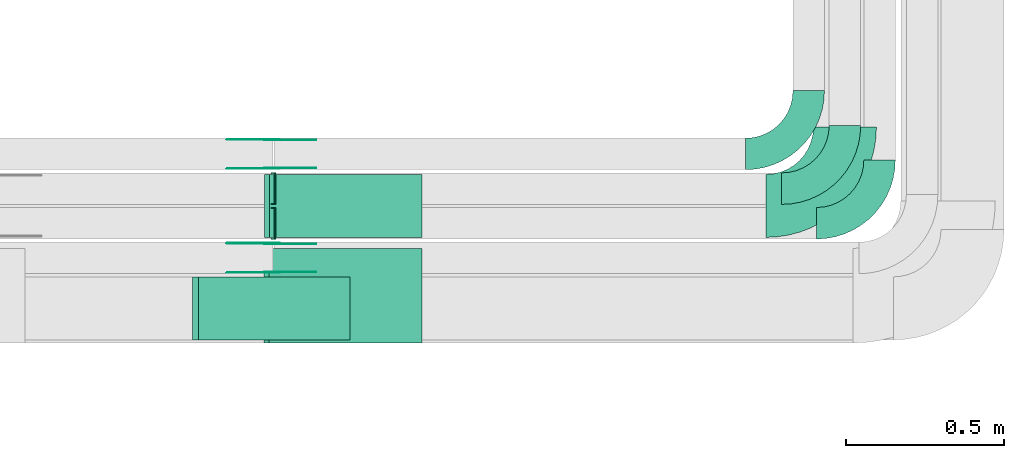
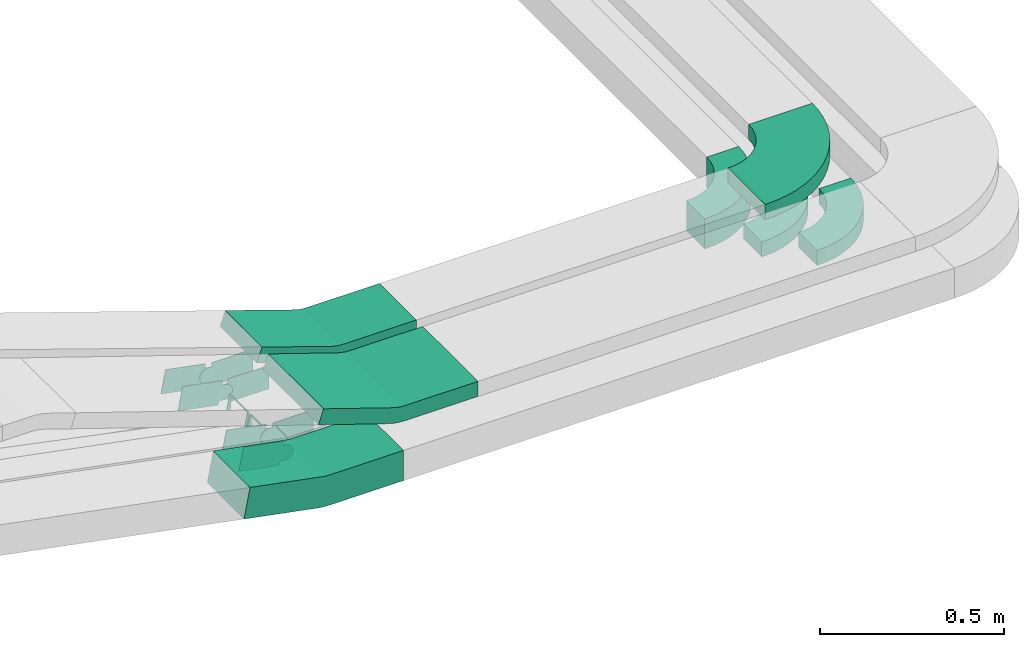
# One storey, part 28 of 31: 17 flow fittings.
"""IFC2X3 building model written with IfcOpenShell, lengths in millimetres."""

from ifc_helpers import new_model, entity, si_unit, converted_unit, derived_unit, direction, frame, frame_2d, origin, place, context, subcontext, project, spatial, polyline, circle_curve, parameter, trimmed, segment, composite_curve, outline, extrude, faceted_brep, source, transform, mapped, material, type_object, type_shapes, element, save


model = new_model("IFC2X3")

# Units and contexts
model_context = context("Model", 3, precision=0.01, world=origin(), true_north=direction((6.12303176911189e-17, 1.0)))
body_context = subcontext(model_context, "Body", "Model", "MODEL_VIEW")
ifc_project = project(units=[si_unit("LENGTHUNIT", "METRE", prefix="MILLI"), si_unit("AREAUNIT", "SQUARE_METRE"), si_unit("VOLUMEUNIT", "CUBIC_METRE"), converted_unit("PLANEANGLEUNIT", "DEGREE", entity("IfcRatioMeasure", 0.0174532925199433), si_unit("PLANEANGLEUNIT", "RADIAN"), dimensions=[0, 0, 0, 0, 0, 0, 0]), si_unit("MASSUNIT", "GRAM", prefix="KILO"), derived_unit("MASSDENSITYUNIT", [(si_unit("MASSUNIT", "GRAM", prefix="KILO"), 1), (si_unit("LENGTHUNIT", "METRE"), -3)]), derived_unit("MOMENTOFINERTIAUNIT", [(si_unit("LENGTHUNIT", "METRE"), 4)]), si_unit("TIMEUNIT", "SECOND"), si_unit("FREQUENCYUNIT", "HERTZ"), si_unit("THERMODYNAMICTEMPERATUREUNIT", "DEGREE_CELSIUS"), derived_unit("THERMALTRANSMITTANCEUNIT", [(si_unit("MASSUNIT", "GRAM", prefix="KILO"), 1), (si_unit("THERMODYNAMICTEMPERATUREUNIT", "KELVIN"), -1), (si_unit("TIMEUNIT", "SECOND"), -3)]), derived_unit("VOLUMETRICFLOWRATEUNIT", [(si_unit("LENGTHUNIT", "METRE"), 3), (si_unit("TIMEUNIT", "SECOND"), -1)]), derived_unit("MASSFLOWRATEUNIT", [(si_unit("MASSUNIT", "GRAM", prefix="KILO"), 1), (si_unit("TIMEUNIT", "SECOND"), -1)]), derived_unit("ROTATIONALFREQUENCYUNIT", [(si_unit("TIMEUNIT", "SECOND"), -1)]), si_unit("ELECTRICCURRENTUNIT", "AMPERE"), si_unit("ELECTRICVOLTAGEUNIT", "VOLT"), si_unit("POWERUNIT", "WATT"), si_unit("FORCEUNIT", "NEWTON", prefix="KILO"), si_unit("ILLUMINANCEUNIT", "LUX"), si_unit("LUMINOUSFLUXUNIT", "LUMEN"), si_unit("LUMINOUSINTENSITYUNIT", "CANDELA"), derived_unit("USERDEFINED", [(si_unit("MASSUNIT", "GRAM", prefix="KILO"), -1), (si_unit("LENGTHUNIT", "METRE"), -2), (si_unit("TIMEUNIT", "SECOND"), 3), (si_unit("LUMINOUSFLUXUNIT", "LUMEN"), 1)]), derived_unit("LINEARVELOCITYUNIT", [(si_unit("LENGTHUNIT", "METRE"), 1), (si_unit("TIMEUNIT", "SECOND"), -1)]), si_unit("PRESSUREUNIT", "PASCAL"), derived_unit("USERDEFINED", [(si_unit("LENGTHUNIT", "METRE"), -2), (si_unit("MASSUNIT", "GRAM", prefix="KILO"), 1), (si_unit("TIMEUNIT", "SECOND"), -2)]), derived_unit("LINEARFORCEUNIT", [(si_unit("MASSUNIT", "GRAM", prefix="KILO"), 1), (si_unit("LENGTHUNIT", "METRE"), 1), (si_unit("TIMEUNIT", "SECOND"), -2), (si_unit("LENGTHUNIT", "METRE"), -1)]), derived_unit("PLANARFORCEUNIT", [(si_unit("MASSUNIT", "GRAM", prefix="KILO"), 1), (si_unit("LENGTHUNIT", "METRE"), 1), (si_unit("TIMEUNIT", "SECOND"), -2), (si_unit("LENGTHUNIT", "METRE"), -2)])], contexts=[model_context])

# Site, building, storey
site_placement = place(None, frame((0.0, -0.00077364408347762, 0.0)))
site = spatial("IfcSite", under=ifc_project, at=site_placement, CompositionType="ELEMENT")
building_placement = place(site_placement, origin())
building = spatial("IfcBuilding", under=site, at=building_placement, CompositionType="ELEMENT")
storey_placement = place(building_placement, frame((0.0, 0.0, 15900.0)))
storey = spatial("IfcBuildingStorey", under=building, at=storey_placement, CompositionType="ELEMENT", Elevation=15900.0)

# Flow fittings
ifc_material_1 = material()
cable_carrier_fitting_type_1 = type_object("IfcCableCarrierFittingType", Name="470_DKC_S5_Variable Angle Elbow 0-45:-", PredefinedType="NOTDEFINED", material=ifc_material_1)
shared_shape_1 = source(origin(), body_context, "Body", "SweptSolid", [
    extrude(outline(composite_curve([segment(polyline([(-100.749999999999, -150.250000000001), (-99.7499999999981, -150.250000000001)]), True, "CONTINUOUS"), segment(trimmed(circle_curve(frame_2d((-99.7500000000006, 99.7499999999987), x_axis=(0.0, -1.0)), 250.0), [parameter(0.0)], [parameter(90.0000000000001)], True, "PARAMETER"), True, "CONTINUOUS"), segment(polyline([(150.249999999999, 99.7500000000013), (150.249999999999, 100.750000000001)]), True, "CONTINUOUS"), segment(polyline([(150.249999999999, 100.750000000001), (50.2499999999992, 100.750000000001)]), True, "CONTINUOUS"), segment(polyline([(50.2499999999992, 100.750000000001), (50.2499999999992, 99.7500000000002)]), True, "CONTINUOUS"), segment(trimmed(circle_curve(frame_2d((-99.7500000000006, 99.7499999999987), x_axis=(0.0, -1.0)), 150.0), [parameter(0.0)], [parameter(90.0000000000001)], True, "PARAMETER"), False, "CONTINUOUS"), segment(polyline([(-99.7499999999989, -50.2500000000011), (-100.75, -50.2500000000011)]), True, "CONTINUOUS"), segment(polyline([(-100.75, -50.2500000000011), (-100.749999999999, -150.250000000001)]), True, "CONTINUOUS")], self_intersect=False)), frame((-100.249999999991, 100.249999999992, -50.0)), (0.0, 0.0, 1.0), 100.0),
])
type_shapes(cable_carrier_fitting_type_1, [shared_shape_1])
flow_fitting_1_placement = place(storey_placement, frame((68357.9446589115, 9064.96586239508, 2645.87316402395)))
element("IfcFlowFitting", 1, at=flow_fitting_1_placement, inside=storey, type_object=cable_carrier_fitting_type_1, material=ifc_material_1, Name="470_DKC_S5_Variable Angle Elbow 0-45:-", ObjectType="470_DKC_S5_Variable Angle Elbow 0-45:-", context=body_context, shape_type="MappedRepresentation", body=[
    mapped(shared_shape_1, transform((0.0, 0.0, 0.0), scale=1.0)),
])
cable_carrier_fitting_type_2 = type_object("IfcCableCarrierFittingType", Name="470_DKC_S5_Variable Angle Elbow 0-45:-", PredefinedType="NOTDEFINED", material=ifc_material_1)
shared_shape_2 = source(origin(), body_context, "Body", "SweptSolid", [
    extrude(outline(composite_curve([segment(polyline([(-100.750000000001, -150.25), (-99.7499999999994, -150.25)]), True, "CONTINUOUS"), segment(trimmed(circle_curve(frame_2d((-99.7499999999997, 99.7499999999995), x_axis=(0.0, -1.0)), 250.0), [parameter(0.0)], [parameter(90.0000000000001)], True, "PARAMETER"), True, "CONTINUOUS"), segment(polyline([(150.25, 99.75), (150.25, 100.749999999999)]), True, "CONTINUOUS"), segment(polyline([(150.25, 100.749999999999), (50.25, 100.75)]), True, "CONTINUOUS"), segment(polyline([(50.25, 100.75), (50.25, 99.7499999999998)]), True, "CONTINUOUS"), segment(trimmed(circle_curve(frame_2d((-99.7499999999997, 99.7499999999995), x_axis=(0.0, -1.0)), 150.0), [parameter(0.0)], [parameter(90.0000000000001)], True, "PARAMETER"), False, "CONTINUOUS"), segment(polyline([(-99.7499999999994, -50.2500000000003), (-100.750000000001, -50.2500000000003)]), True, "CONTINUOUS"), segment(polyline([(-100.750000000001, -50.2500000000003), (-100.750000000001, -150.25)]), True, "CONTINUOUS")], self_intersect=False)), frame((-100.249999999991, 100.249999999992, -25.0)), (0.0, 0.0, 1.0), 49.9999999999997),
])
type_shapes(cable_carrier_fitting_type_2, [shared_shape_2])
for number, where, name in (
    (2, (68472.9446589115, 8954.96586239508, 2620.87316402394), "470_DKC_S5_Variable Angle Elbow 0-45:-"),
    (3, (68582.9446589115, 8844.96586239508, 2620.87316402394), "470_DKC_S5_Variable Angle Elbow 0-45:-"),
):
    element("IfcFlowFitting", number, at=place(storey_placement, frame(where)), inside=storey, type_object=cable_carrier_fitting_type_2, material=ifc_material_1, Name=name, ObjectType="470_DKC_S5_Variable Angle Elbow 0-45:-", context=body_context, shape_type="MappedRepresentation", body=[
        mapped(shared_shape_2, transform((0.0, 0.0, 0.0), scale=1.0)),
    ])
cable_carrier_fitting_type_3 = type_object("IfcCableCarrierFittingType", Name="470_DKC_S5_Variable Angle Elbow 0-45:-", PredefinedType="NOTDEFINED", material=ifc_material_1)
shared_shape_3 = source(origin(), body_context, "Body", "SweptSolid", [
    extrude(outline(composite_curve([segment(polyline([(-125.750000000004, -225.249999999998), (-124.750000000003, -225.249999999998)]), True, "CONTINUOUS"), segment(trimmed(circle_curve(frame_2d((-124.749999999998, 124.750000000002), x_axis=(0.0, -1.0)), 350.0), [parameter(0.0)], [parameter(90.0)], True, "PARAMETER"), True, "CONTINUOUS"), segment(polyline([(225.250000000002, 124.749999999996), (225.250000000002, 125.749999999995)]), True, "CONTINUOUS"), segment(polyline([(225.250000000002, 125.749999999995), (25.2500000000021, 125.750000000001)]), True, "CONTINUOUS"), segment(polyline([(25.2500000000021, 125.750000000001), (25.2500000000021, 124.749999999999)]), True, "CONTINUOUS"), segment(trimmed(circle_curve(frame_2d((-124.749999999998, 124.750000000002), x_axis=(0.0, -1.0)), 150.0), [parameter(0.0)], [parameter(90.0)], True, "PARAMETER"), False, "CONTINUOUS"), segment(polyline([(-124.75, -25.2499999999979), (-125.750000000001, -25.2499999999979)]), True, "CONTINUOUS"), segment(polyline([(-125.750000000001, -25.2499999999979), (-125.750000000004, -225.249999999998)]), True, "CONTINUOUS")], self_intersect=False)), frame((-125.249999999991, 125.249999999992, -25.0)), (0.0, 0.0, 1.0), 50.000000000001),
])
type_shapes(cable_carrier_fitting_type_3, [shared_shape_3])
flow_fitting_2_placement = place(storey_placement, frame((68472.9446589116, 8900.14842319196, 2825.87316402393)))
element("IfcFlowFitting", 4, at=flow_fitting_2_placement, inside=storey, type_object=cable_carrier_fitting_type_3, material=ifc_material_1, Name="470_DKC_S5_Variable Angle Elbow 0-45:-", ObjectType="470_DKC_S5_Variable Angle Elbow 0-45:-", context=body_context, shape_type="MappedRepresentation", body=[
    mapped(shared_shape_3, transform((0.0, 0.0, 0.0), scale=1.0)),
])
ifc_material_2 = material(Name="G")
cable_carrier_fitting_type_4 = type_object("IfcCableCarrierFittingType", PredefinedType="NOTDEFINED", material=ifc_material_2)
shared_shape_4 = source(origin(), body_context, "Body", "SweptSolid", [
    extrude(outline(composite_curve([segment(trimmed(circle_curve(frame_2d((-41.4651162790697, 0.0), x_axis=(1.0, 0.0)), 25.0), [parameter(90.0000000000007)], [parameter(270.0)], True, "PARAMETER"), True, "CONTINUOUS"), segment(polyline([(-41.4651162790697, -25.0), (-29.9651162790697, -25.0)]), True, "CONTINUOUS"), segment(polyline([(-29.9651162790697, -25.0), (-28.1046511627907, -38.5)]), True, "CONTINUOUS"), segment(polyline([(-28.1046511627907, -38.5), (99.5348837209303, -38.5)]), True, "CONTINUOUS"), segment(polyline([(99.5348837209303, -38.5), (99.5348837209303, 38.5)]), True, "CONTINUOUS"), segment(polyline([(99.5348837209303, 38.5), (-28.1046511627907, 38.5)]), True, "CONTINUOUS"), segment(polyline([(-28.1046511627907, 38.5), (-29.9651162790697, 25.0)]), True, "CONTINUOUS"), segment(polyline([(-29.9651162790697, 25.0), (-41.46511627907, 25.0)]), True, "CONTINUOUS")], self_intersect=False)), frame((41.4651162790697, 0.0, 0.0), z_axis=(0.0, 0.0, -1.0), x_axis=(1.0, 0.0, 0.0)), (0.0, 0.0, -1.0), 2.0),
])
type_shapes(cable_carrier_fitting_type_4, [shared_shape_4])
for number, where, z_axis, x_axis in (
    (5, (66654.1833662233, 8780.42586240513, 2645.87316402391), (0.0, 1.0, 0.0), (-0.982035536310358, 0.0, 0.188696066264316)),
    (6, (66654.1833662233, 9110.42586240521, 2645.87316402392), (0.0, 1.0, 0.0), (-0.982035536310358, 0.0, 0.188696066264316)),
):
    element("IfcFlowFitting", number, at=place(storey_placement, frame(where, z_axis=z_axis, x_axis=x_axis)), inside=storey, type_object=cable_carrier_fitting_type_4, material=ifc_material_2, context=body_context, shape_type="MappedRepresentation", body=[
        mapped(shared_shape_4, transform((0.0, 0.0, 0.0), scale=1.0)),
    ])
cable_carrier_fitting_type_5 = type_object("IfcCableCarrierFittingType", PredefinedType="NOTDEFINED", material=ifc_material_2)
shared_shape_5 = source(origin(), body_context, "Body", "SweptSolid", [
    extrude(outline(composite_curve([segment(trimmed(circle_curve(frame_2d((-41.4651162790697, 0.0), x_axis=(1.0, 0.0)), 25.0), [parameter(90.0000000000007)], [parameter(270.0)], True, "PARAMETER"), True, "CONTINUOUS"), segment(polyline([(-41.4651162790697, -25.0), (-29.9651162790697, -25.0)]), True, "CONTINUOUS"), segment(polyline([(-29.9651162790697, -25.0), (-28.1046511627907, -38.5)]), True, "CONTINUOUS"), segment(polyline([(-28.1046511627907, -38.5), (99.5348837209303, -38.5)]), True, "CONTINUOUS"), segment(polyline([(99.5348837209303, -38.5), (99.5348837209303, 38.5)]), True, "CONTINUOUS"), segment(polyline([(99.5348837209303, 38.5), (-28.1046511627907, 38.5)]), True, "CONTINUOUS"), segment(polyline([(-28.1046511627907, 38.5), (-29.9651162790697, 25.0)]), True, "CONTINUOUS"), segment(polyline([(-29.9651162790697, 25.0), (-41.46511627907, 25.0)]), True, "CONTINUOUS")], self_intersect=False)), frame((41.4651162790697, 0.0, 0.0)), (0.0, 0.0, 1.0), 2.0),
])
type_shapes(cable_carrier_fitting_type_5, [shared_shape_5])
for number, where, z_axis, x_axis in (
    (7, (66654.1833662233, 8689.50586238482, 2645.87316402391), (0.0, -1.0, 0.0), (-0.982035536310358, 0.0, 0.188696066264316)),
    (8, (66654.1833662233, 9019.50586238489, 2645.87316402392), (0.0, -1.0, 0.0), (-0.982035536310358, 0.0, 0.188696066264316)),
):
    element("IfcFlowFitting", number, at=place(storey_placement, frame(where, z_axis=z_axis, x_axis=x_axis)), inside=storey, type_object=cable_carrier_fitting_type_5, material=ifc_material_2, context=body_context, shape_type="MappedRepresentation", body=[
        mapped(shared_shape_5, transform((0.0, 0.0, 0.0), scale=1.0)),
    ])
cable_carrier_fitting_type_6 = type_object("IfcCableCarrierFittingType", PredefinedType="NOTDEFINED", material=ifc_material_2)
shared_shape_6 = source(origin(), body_context, "Body", "SweptSolid", [
    extrude(outline(composite_curve([segment(trimmed(circle_curve(frame_2d((-41.4651162790697, 0.0), x_axis=(1.0, 0.0)), 25.0), [parameter(90.0000000000007)], [parameter(270.0)], True, "PARAMETER"), True, "CONTINUOUS"), segment(polyline([(-41.4651162790697, -25.0), (-29.9651162790697, -25.0)]), True, "CONTINUOUS"), segment(polyline([(-29.9651162790697, -25.0), (-28.1046511627907, -38.5)]), True, "CONTINUOUS"), segment(polyline([(-28.1046511627907, -38.5), (99.5348837209303, -38.5)]), True, "CONTINUOUS"), segment(polyline([(99.5348837209303, -38.5), (99.5348837209303, 38.5)]), True, "CONTINUOUS"), segment(polyline([(99.5348837209303, 38.5), (-28.1046511627907, 38.5)]), True, "CONTINUOUS"), segment(polyline([(-28.1046511627907, 38.5), (-29.9651162790697, 25.0)]), True, "CONTINUOUS"), segment(polyline([(-29.9651162790697, 25.0), (-41.46511627907, 25.0)]), True, "CONTINUOUS")], self_intersect=False)), frame((41.4651162790697, 0.0, 0.0), z_axis=(0.0, 0.0, -1.0), x_axis=(1.0, 0.0, 0.0)), (0.0, 0.0, -1.0), 2.0),
])
type_shapes(cable_carrier_fitting_type_6, [shared_shape_6])
for number, where, z_axis, x_axis in (
    (9, (66654.1833662233, 8691.50586238481, 2645.87316402392), (0.0, -1.0, 0.0), (1.0, 0.0, 0.0)),
    (10, (66654.1833662233, 9021.50586238489, 2645.87316402392), (0.0, -1.0, 0.0), (1.0, 0.0, 0.0)),
):
    element("IfcFlowFitting", number, at=place(storey_placement, frame(where, z_axis=z_axis, x_axis=x_axis)), inside=storey, type_object=cable_carrier_fitting_type_6, material=ifc_material_2, context=body_context, shape_type="MappedRepresentation", body=[
        mapped(shared_shape_6, transform((0.0, 0.0, 0.0), scale=1.0)),
    ])
cable_carrier_fitting_type_7 = type_object("IfcCableCarrierFittingType", PredefinedType="NOTDEFINED", material=ifc_material_2)
shared_shape_7 = source(origin(), body_context, "Body", "SweptSolid", [
    extrude(outline(composite_curve([segment(trimmed(circle_curve(frame_2d((-41.4651162790697, 0.0), x_axis=(1.0, 0.0)), 25.0), [parameter(90.0000000000007)], [parameter(270.0)], True, "PARAMETER"), True, "CONTINUOUS"), segment(polyline([(-41.4651162790697, -25.0), (-29.9651162790697, -25.0)]), True, "CONTINUOUS"), segment(polyline([(-29.9651162790697, -25.0), (-28.1046511627907, -38.5)]), True, "CONTINUOUS"), segment(polyline([(-28.1046511627907, -38.5), (99.5348837209303, -38.5)]), True, "CONTINUOUS"), segment(polyline([(99.5348837209303, -38.5), (99.5348837209303, 38.5)]), True, "CONTINUOUS"), segment(polyline([(99.5348837209303, 38.5), (-28.1046511627907, 38.5)]), True, "CONTINUOUS"), segment(polyline([(-28.1046511627907, 38.5), (-29.9651162790697, 25.0)]), True, "CONTINUOUS"), segment(polyline([(-29.9651162790697, 25.0), (-41.46511627907, 25.0)]), True, "CONTINUOUS")], self_intersect=False)), frame((41.4651162790697, 0.0, 0.0)), (0.0, 0.0, 1.0), 2.0),
])
type_shapes(cable_carrier_fitting_type_7, [shared_shape_7])
for number, where, z_axis, x_axis in (
    (11, (66654.1833662233, 8778.42586240513, 2645.87316402392), (0.0, 1.0, 0.0), (1.0, 0.0, 0.0)),
    (12, (66654.1833662233, 9108.42586240521, 2645.87316402393), (0.0, 1.0, 0.0), (1.0, 0.0, 0.0)),
):
    element("IfcFlowFitting", number, at=place(storey_placement, frame(where, z_axis=z_axis, x_axis=x_axis)), inside=storey, type_object=cable_carrier_fitting_type_7, material=ifc_material_2, context=body_context, shape_type="MappedRepresentation", body=[
        mapped(shared_shape_7, transform((0.0, 0.0, 0.0), scale=1.0)),
    ])
cable_carrier_fitting_type_8 = type_object("IfcCableCarrierFittingType", Name="470_DKC_S5_CS 90 internal vertical angle:-", PredefinedType="NOTDEFINED", material=ifc_material_1)
shared_shape_8 = source(origin(), body_context, "Body", "SweptSolid", [
    extrude(outline(composite_curve([segment(polyline([(-246.323626570813, -62.4168745908477), (-14.5263972393851, -62.4168745908477)]), True, "CONTINUOUS"), segment(trimmed(circle_curve(frame_2d((-14.5263972393855, 152.583125409151), x_axis=(0.0, -1.0)), 214.999999999999), [parameter(0.0)], [parameter(10.876697894602)], True, "PARAMETER"), True, "CONTINUOUS"), segment(polyline([(26.0432570074432, -58.5545148975746), (253.676373429187, -14.8152895517661)]), True, "CONTINUOUS"), segment(polyline([(253.676373429187, -14.8152895517661), (234.806766802755, 83.3882640792699)]), True, "CONTINUOUS"), segment(polyline([(234.806766802755, 83.3882640792699), (7.17365038101109, 39.6490387334614)]), True, "CONTINUOUS"), segment(trimmed(circle_curve(frame_2d((-14.5263972393855, 152.583125409151), x_axis=(0.0, -1.0)), 114.999999999999), [parameter(0.0)], [parameter(10.876697894602)], True, "PARAMETER"), False, "CONTINUOUS"), segment(polyline([(-14.5263972393851, 37.5831254091525), (-246.323626570813, 37.5831254091526)]), True, "CONTINUOUS"), segment(polyline([(-246.323626570813, 37.5831254091526), (-246.323626570813, -62.4168745908477)]), True, "CONTINUOUS")], self_intersect=False)), frame((-1.18212582350271, 12.4168745908404, -100.0)), (0.0, 0.0, 1.0), 200.0),
])
type_shapes(cable_carrier_fitting_type_8, [shared_shape_8])
flow_fitting_3_placement = place(storey_placement, frame((66654.1833662233, 8574.9658623949, 2645.87316402394), z_axis=(0.0, 1.0, 0.0), x_axis=(-1.0, 0.0, 0.0)))
element("IfcFlowFitting", 13, at=flow_fitting_3_placement, inside=storey, type_object=cable_carrier_fitting_type_8, material=ifc_material_1, Name="470_DKC_S5_CS 90 internal vertical angle:-", ObjectType="470_DKC_S5_CS 90 internal vertical angle:-", context=body_context, shape_type="MappedRepresentation", body=[
    mapped(shared_shape_8, transform((0.0, 0.0, 0.0), scale=1.0)),
])
cable_carrier_fitting_type_9 = type_object("IfcCableCarrierFittingType", Name="470_DKC_S5_CS 90 internal vertical angle:-", PredefinedType="NOTDEFINED", material=ifc_material_1)
shared_shape_9 = source(origin(), body_context, "Body", "SweptSolid", [
    extrude(outline(composite_curve([segment(polyline([(-248.994095059935, -46.7434948756321), (-19.176660120537, -46.7434948756321)]), True, "CONTINUOUS"), segment(trimmed(circle_curve(frame_2d((-19.1766601205372, 118.256505124367), x_axis=(0.0, -1.0)), 164.999999999999), [parameter(0.0)], [parameter(18.4219865734393)], True, "PARAMETER"), True, "CONTINUOUS"), segment(polyline([(32.9655069190793, -38.2880393874506), (251.005904940065, 34.3372883775574)]), True, "CONTINUOUS"), segment(polyline([(251.005904940065, 34.3372883775573), (235.205248261393, 81.7750291387147)]), True, "CONTINUOUS"), segment(polyline([(235.205248261393, 81.7750291387147), (17.1648502404074, 9.14970137370676)]), True, "CONTINUOUS"), segment(trimmed(circle_curve(frame_2d((-19.1766601205372, 118.256505124367), x_axis=(0.0, -1.0)), 114.999999999999), [parameter(0.0)], [parameter(18.4219865734393)], True, "PARAMETER"), False, "CONTINUOUS"), segment(polyline([(-19.176660120537, 3.25650512436813), (-248.994095059935, 3.25650512436815)]), True, "CONTINUOUS"), segment(polyline([(-248.994095059935, 3.25650512436815), (-248.994095059935, -46.7434948756321)]), True, "CONTINUOUS")], self_intersect=False)), frame((-3.52595919034708, 21.7434948756249, -150.0)), (0.0, 0.0, 1.0), 300.0),
])
type_shapes(cable_carrier_fitting_type_9, [shared_shape_9])
flow_fitting_4_placement = place(storey_placement, frame((66877.0477941578, 8615.14842319196, 2825.87316402398), z_axis=(0.0, 1.0, 0.0), x_axis=(-1.0, 0.0, 0.0)))
element("IfcFlowFitting", 14, at=flow_fitting_4_placement, inside=storey, type_object=cable_carrier_fitting_type_9, material=ifc_material_1, Name="470_DKC_S5_CS 90 internal vertical angle:-", ObjectType="470_DKC_S5_CS 90 internal vertical angle:-", context=body_context, shape_type="MappedRepresentation", body=[
    mapped(shared_shape_9, transform((0.0, 0.0, 0.0), scale=1.0)),
])
cable_carrier_fitting_type_10 = type_object("IfcCableCarrierFittingType", PredefinedType="NOTDEFINED", material=ifc_material_1)
shared_shape_10 = source(origin(), body_context, "Body", "Brep", [
    faceted_brep([(-5.06072137132877, 25.0, 50.0), (-5.06072137132877, 25.0, -50.0), (-5.06072137132893, -25.0, -50.0), (-5.06072137132893, -25.0, -47.4600000101565), (-5.06072137132878, 22.46000001016, -47.4600000101565), (-5.06072137132878, 22.46000001016, 47.4600000101635), (-5.06072137132893, -25.0, 47.4600000101635), (-5.06072137132893, -25.0, 50.0), (-0.051318131770118, 25.5070238806404, 50.0), (9.96748834734716, -23.478928358078, 50.0), (9.96748834734716, -23.478928358078, 47.4600000101635), (0.45763723533322, 23.0185375168674, 47.4600000101635), (0.457637235333217, 23.0185375168674, -47.4600000101565), (9.96748834734716, -23.478928358078, -47.4600000101565), (9.96748834734717, -23.478928358078, -50.0), (-0.051318131770118, 25.5070238806404, -50.0), (-2.53036068566412, 25.0, 50.0), (-2.53036068566416, 25.0, -50.0), (2.53036068566507, -25.0, -50.0), (2.53036068566507, -25.0, -47.4600000101565), (-2.27327604102898, 22.46000001016, -47.4600000101565), (-2.27327604102898, 22.46000001016, 47.4600000101635), (2.53036068566507, -25.0, 47.4600000101635), (2.53036068566507, -25.0, 50.0)], [[[0, 1, 2, 3, 4, 5, 6, 7]], [[8, 9, 10, 11, 12, 13, 14, 15]], [[1, 0, 16, 17]], [[2, 1, 17, 15, 14, 18]], [[3, 2, 18, 19]], [[4, 3, 19, 13, 12, 20]], [[5, 4, 20, 21]], [[6, 5, 21, 11, 10, 22]], [[7, 6, 22, 23]], [[0, 7, 23, 9, 8, 16]], [[17, 16, 8, 15]], [[19, 18, 14, 13]], [[21, 20, 12, 11]], [[23, 22, 10, 9]]]),
])
type_shapes(cable_carrier_fitting_type_10, [shared_shape_10])
flow_fitting_5_placement = place(storey_placement, frame((66661.5639695322, 8844.96586239506, 2620.87316402394), z_axis=(0.0, 1.0, 0.0), x_axis=(-1.0, 0.0, 0.0)))
element("IfcFlowFitting", 15, at=flow_fitting_5_placement, inside=storey, type_object=cable_carrier_fitting_type_10, material=ifc_material_1, context=body_context, shape_type="MappedRepresentation", body=[
    mapped(shared_shape_10, transform((0.0, 0.0, 0.0), scale=1.0)),
])
cable_carrier_fitting_type_11 = type_object("IfcCableCarrierFittingType", PredefinedType="NOTDEFINED", material=ifc_material_1)
shared_shape_11 = source(origin(), body_context, "Body", "Brep", [
    faceted_brep([(-4.70112561692858, 25.0, 50.0), (-4.70112561692858, 25.0, -50.0), (-4.70112561692874, -25.0, -50.0), (-4.70112561692874, -25.0, -47.4600000101565), (-4.70112561692858, 22.46000001016, -47.4600000101565), (-4.70112561692858, 22.46000001016, 47.4600000101635), (-4.70112561692874, -25.0, 47.4600000101635), (-4.70112561692874, -25.0, 50.0), (-0.0411948727333111, 25.4381383958926, 50.0), (9.27866661565716, -23.6855848123214, 50.0), (9.27866661565716, -23.6855848123214, 47.4600000101635), (0.432254088983129, 22.9426532668972, 47.4600000101635), (0.43225408898313, 22.9426532668972, -47.4600000101565), (9.27866661565716, -23.6855848123214, -47.4600000101565), (9.27866661565716, -23.6855848123214, -50.0), (-0.0411948727333111, 25.4381383958926, -50.0), (-2.35056280846401, 25.0, 50.0), (-2.35056280846405, 25.0, -50.0), (2.35056280846497, -25.0, -50.0), (2.35056280846497, -25.0, -47.4600000101565), (-2.11174562807933, 22.46000001016, -47.4600000101565), (-2.11174562807933, 22.46000001016, 47.4600000101635), (2.35056280846497, -25.0, 47.4600000101635), (2.35056280846497, -25.0, 50.0)], [[[0, 1, 2, 3, 4, 5, 6, 7]], [[8, 9, 10, 11, 12, 13, 14, 15]], [[1, 0, 16, 17]], [[2, 1, 17, 15, 14, 18]], [[3, 2, 18, 19]], [[4, 3, 19, 13, 12, 20]], [[5, 4, 20, 21]], [[6, 5, 21, 11, 10, 22]], [[7, 6, 22, 23]], [[0, 7, 23, 9, 8, 16]], [[17, 16, 8, 15]], [[19, 18, 14, 13]], [[21, 20, 12, 11]], [[23, 22, 10, 9]]]),
])
type_shapes(cable_carrier_fitting_type_11, [shared_shape_11])
flow_fitting_6_placement = place(storey_placement, frame((66661.5639695322, 8954.96586239505, 2620.87316402394), z_axis=(0.0, 1.0, 0.0), x_axis=(-1.0, 0.0, 0.0)))
element("IfcFlowFitting", 16, at=flow_fitting_6_placement, inside=storey, type_object=cable_carrier_fitting_type_11, material=ifc_material_1, context=body_context, shape_type="MappedRepresentation", body=[
    mapped(shared_shape_11, transform((0.0, 0.0, 0.0), scale=1.0)),
])
cable_carrier_fitting_type_12 = type_object("IfcCableCarrierFittingType", Name="470_DKC_S5_CS 90 internal vertical angle:-", PredefinedType="NOTDEFINED", material=ifc_material_1)
shared_shape_12 = source(origin(), body_context, "Body", "SweptSolid", [
    extrude(outline(composite_curve([segment(polyline([(-249.026048854323, -47.141348445143), (-19.4404131653476, -47.141348445143)]), True, "CONTINUOUS"), segment(trimmed(circle_curve(frame_2d((-19.4404131653479, 117.858651554856), x_axis=(0.0, -1.0)), 164.999999999999), [parameter(0.0)], [parameter(18.7328408756737)], True, "PARAMETER"), True, "CONTINUOUS"), segment(polyline([(33.5503039345774, -38.4006966494526), (250.973951145677, 35.3320759020687)]), True, "CONTINUOUS"), segment(polyline([(250.973951145677, 35.3320759020687), (234.916158085093, 82.6833935397385)]), True, "CONTINUOUS"), segment(polyline([(234.916158085093, 82.6833935397385), (17.4925108739938, 8.95062098821718)]), True, "CONTINUOUS"), segment(trimmed(circle_curve(frame_2d((-19.4404131653479, 117.858651554856), x_axis=(0.0, -1.0)), 114.999999999999), [parameter(0.0)], [parameter(18.7328408756737)], True, "PARAMETER"), False, "CONTINUOUS"), segment(polyline([(-19.4404131653476, 2.85865155485721), (-249.026048854323, 2.85865155485722)]), True, "CONTINUOUS"), segment(polyline([(-249.026048854323, 2.85865155485722), (-249.026048854323, -47.141348445143)]), True, "CONTINUOUS")], self_intersect=False)), frame((-3.65214565186259, 22.1413484451357, -100.0)), (0.0, 0.0, 1.0), 200.0),
])
type_shapes(cable_carrier_fitting_type_12, [shared_shape_12])
flow_fitting_7_placement = place(storey_placement, frame((66877.047794158, 8900.14842319195, 2825.87316402394), z_axis=(0.0, 1.0, 0.0), x_axis=(-1.0, 0.0, 0.0)))
element("IfcFlowFitting", 17, at=flow_fitting_7_placement, inside=storey, type_object=cable_carrier_fitting_type_12, material=ifc_material_1, Name="470_DKC_S5_CS 90 internal vertical angle:-", ObjectType="470_DKC_S5_CS 90 internal vertical angle:-", context=body_context, shape_type="MappedRepresentation", body=[
    mapped(shared_shape_12, transform((0.0, 0.0, 0.0), scale=1.0)),
])

save(model, "model.ifc")
